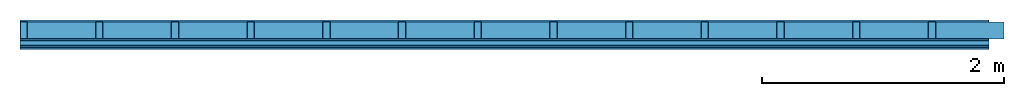
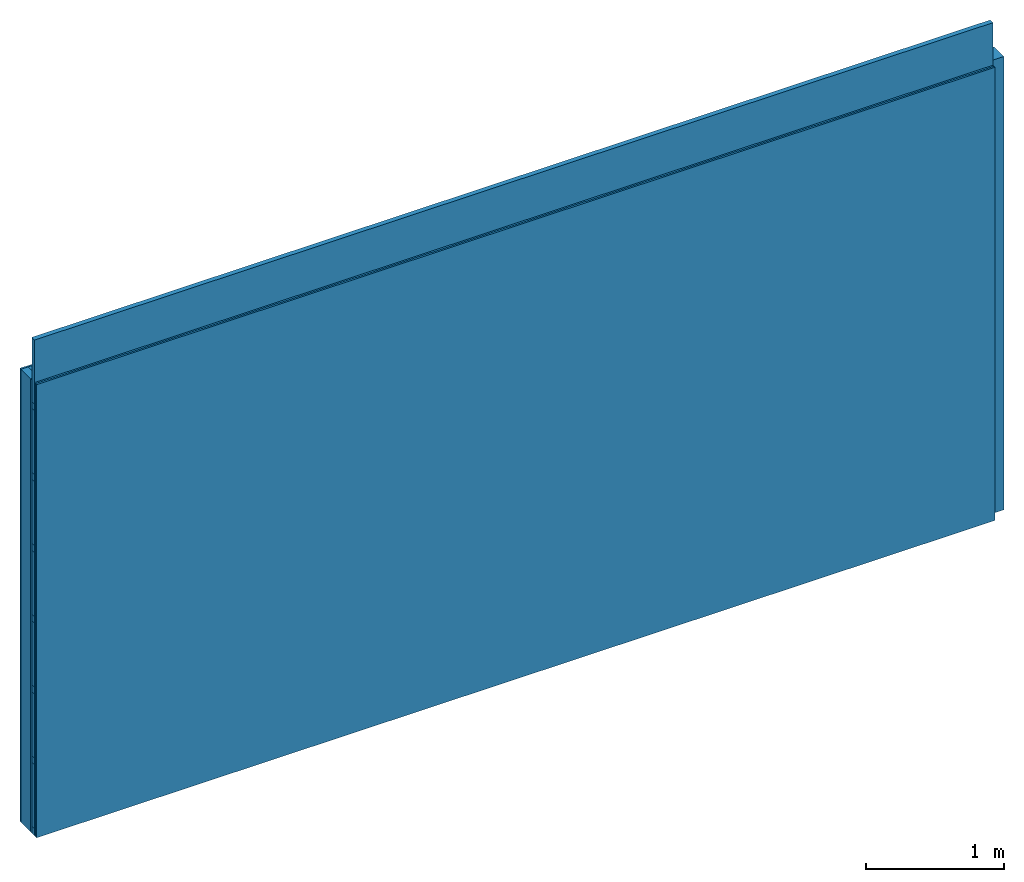
# One storey: 4 members, 4 plates, 1 element without a shape of its own.
"""IFC4 building model written with IfcOpenShell, lengths in metres."""

from ifc_helpers import new_model, si_unit, derived_unit, direction, frame, frame_2d, origin, origin_with_axes, place, context, project, spatial, rectangle, extrude, material, layer, layer_set, type_object, element, aggregate, save


model = new_model("IFC4")

# Units and contexts
plan_context = context("Plan", 3, precision=1e-05, world=origin(), true_north=direction((0.0, 1.0)))
model_context = context("Model", 3, precision=1e-05, world=origin(), true_north=direction((0.0, 1.0)))
ifc_project = project(units=[si_unit("LENGTHUNIT", "METRE"), derived_unit("SOUNDPRESSUREUNIT", [(si_unit("PRESSUREUNIT", "PASCAL", prefix="MICRO"), 0)]), si_unit("ENERGYUNIT", "JOULE", prefix="MEGA"), si_unit("MASSUNIT", "GRAM", prefix="KILO"), derived_unit("THERMALTRANSMITTANCEUNIT", [(si_unit("POWERUNIT", "WATT"), 1), (si_unit("AREAUNIT", "SQUARE_METRE"), -1), (si_unit("THERMODYNAMICTEMPERATUREUNIT", "KELVIN"), -1)]), derived_unit("AREADENSITYUNIT", [(si_unit("MASSUNIT", "GRAM", prefix="KILO"), 1), (si_unit("AREAUNIT", "SQUARE_METRE"), -1)]), derived_unit("USERDEFINED", [(si_unit("ENERGYUNIT", "JOULE", prefix="MEGA"), 1), (si_unit("AREAUNIT", "SQUARE_METRE"), -1)])], contexts=[plan_context, model_context])

# Site, building, storey
site = spatial("IfcSite", under=ifc_project)
building_placement = place(None, origin())
building = spatial("IfcBuilding", under=site, at=building_placement)
storey_placement = place(building_placement, origin())
storey = spatial("IfcBuildingStorey", under=building, at=storey_placement)

# Wall, members, plates
ifc_material_1 = material(Name="Glued joints")
ifc_layer_1 = layer(ifc_material_1, 0.0, Name="Surface")
ifc_material_2 = material(Category="03.007")
ifc_layer_2 = layer(ifc_material_2, 0.015, Name="1st layer")
ifc_material_3 = material(Name="of the art")
ifc_layer_3 = layer(ifc_material_3, 0.0, Name="Bond")
ifc_layer_4 = layer(None, 0.14, Name="Support")
ifc_layer_5 = layer(ifc_material_3, 0.0, Name="Bond")
ifc_layer_6 = layer(ifc_material_2, 0.015, Name="1st layer")
ifc_material_4 = material(Name="Substructure rigid")
ifc_layer_7 = layer(ifc_material_4, 0.0, Name="Coupling")
ifc_layer_8 = layer(None, 0.04, Name="Battens / profiles")
ifc_layer_9 = layer(ifc_material_2, 0.015, Name="Covering 1st layer")
ifc_layer_10 = layer(ifc_material_2, 0.015, Name="Covering 2nd layer")
ifc_layer_11 = layer(ifc_material_1, 0.0, Name="Surface")
ifc_layer_set = layer_set([ifc_layer_1, ifc_layer_2, ifc_layer_3, ifc_layer_4, ifc_layer_5, ifc_layer_6, ifc_layer_7, ifc_layer_8, ifc_layer_9, ifc_layer_10, ifc_layer_11])
wall_type = type_object("IfcWallType", Name="C0077", PredefinedType="NOTDEFINED", material=ifc_layer_set)
wall_placement = place(None, frame((0.0, 0.0, 0.0), z_axis=(0.0, -1.0, 0.0), x_axis=(1.0, 0.0, 0.0)))
wall = element("IfcWall", 1, at=wall_placement, inside=storey, type_object=wall_type, material=ifc_layer_set, Name="Wall #1")
ifc_material_5 = material()
member_1_placement = place(wall_placement, origin())
member_1 = element("IfcMember", 2, at=member_1_placement, material=ifc_material_5, Name="Support", context=plan_context, shape_type="SweptSolid", body=[
    extrude(rectangle(XDim=0.06, YDim=0.14, at=frame_2d((0.03, 0.07), x_axis=(1.0, 0.0))), frame((0.0, 4.0, 0.015), z_axis=(0.0, -1.0, 0.0), x_axis=(1.0, 0.0, 0.0)), (0.0, 0.0, 1.0), 4.0),
    extrude(rectangle(XDim=0.06, YDim=0.14, at=frame_2d((0.03, 0.07), x_axis=(1.0, 0.0))), frame((0.625, 4.0, 0.015), z_axis=(0.0, -1.0, 0.0), x_axis=(1.0, 0.0, 0.0)), (0.0, 0.0, 1.0), 4.0),
    extrude(rectangle(XDim=0.06, YDim=0.14, at=frame_2d((0.03, 0.07), x_axis=(1.0, 0.0))), frame((1.25, 4.0, 0.015), z_axis=(0.0, -1.0, 0.0), x_axis=(1.0, 0.0, 0.0)), (0.0, 0.0, 1.0), 4.0),
    extrude(rectangle(XDim=0.06, YDim=0.14, at=frame_2d((0.03, 0.07), x_axis=(1.0, 0.0))), frame((1.875, 4.0, 0.015), z_axis=(0.0, -1.0, 0.0), x_axis=(1.0, 0.0, 0.0)), (0.0, 0.0, 1.0), 4.0),
    extrude(rectangle(XDim=0.06, YDim=0.14, at=frame_2d((0.03, 0.07), x_axis=(1.0, 0.0))), frame((2.5, 4.0, 0.015), z_axis=(0.0, -1.0, 0.0), x_axis=(1.0, 0.0, 0.0)), (0.0, 0.0, 1.0), 4.0),
    extrude(rectangle(XDim=0.06, YDim=0.14, at=frame_2d((0.03, 0.07), x_axis=(1.0, 0.0))), frame((3.125, 4.0, 0.015), z_axis=(0.0, -1.0, 0.0), x_axis=(1.0, 0.0, 0.0)), (0.0, 0.0, 1.0), 4.0),
    extrude(rectangle(XDim=0.06, YDim=0.14, at=frame_2d((0.03, 0.07), x_axis=(1.0, 0.0))), frame((3.75, 4.0, 0.015), z_axis=(0.0, -1.0, 0.0), x_axis=(1.0, 0.0, 0.0)), (0.0, 0.0, 1.0), 4.0),
    extrude(rectangle(XDim=0.06, YDim=0.14, at=frame_2d((0.03, 0.07), x_axis=(1.0, 0.0))), frame((4.375, 4.0, 0.015), z_axis=(0.0, -1.0, 0.0), x_axis=(1.0, 0.0, 0.0)), (0.0, 0.0, 1.0), 4.0),
    extrude(rectangle(XDim=0.06, YDim=0.14, at=frame_2d((0.03, 0.07), x_axis=(1.0, 0.0))), frame((5.0, 4.0, 0.015), z_axis=(0.0, -1.0, 0.0), x_axis=(1.0, 0.0, 0.0)), (0.0, 0.0, 1.0), 4.0),
    extrude(rectangle(XDim=0.06, YDim=0.14, at=frame_2d((0.03, 0.07), x_axis=(1.0, 0.0))), frame((5.625, 4.0, 0.015), z_axis=(0.0, -1.0, 0.0), x_axis=(1.0, 0.0, 0.0)), (0.0, 0.0, 1.0), 4.0),
    extrude(rectangle(XDim=0.06, YDim=0.14, at=frame_2d((0.03, 0.07), x_axis=(1.0, 0.0))), frame((6.25, 4.0, 0.015), z_axis=(0.0, -1.0, 0.0), x_axis=(1.0, 0.0, 0.0)), (0.0, 0.0, 1.0), 4.0),
    extrude(rectangle(XDim=0.06, YDim=0.14, at=frame_2d((0.03, 0.07), x_axis=(1.0, 0.0))), frame((6.875, 4.0, 0.015), z_axis=(0.0, -1.0, 0.0), x_axis=(1.0, 0.0, 0.0)), (0.0, 0.0, 1.0), 4.0),
    extrude(rectangle(XDim=0.06, YDim=0.14, at=frame_2d((0.03, 0.07), x_axis=(1.0, 0.0))), frame((7.5, 4.0, 0.015), z_axis=(0.0, -1.0, 0.0), x_axis=(1.0, 0.0, 0.0)), (0.0, 0.0, 1.0), 4.0),
])
ifc_material_6 = material()
member_2_placement = place(wall_placement, origin())
member_2 = element("IfcMember", 3, at=member_2_placement, material=ifc_material_6, Name="Cavity", context=plan_context, shape_type="SweptSolid", body=[
    extrude(rectangle(XDim=0.565, YDim=0.14, at=frame_2d((0.2825, 0.07), x_axis=(1.0, 0.0))), frame((0.06, 4.0, 0.015), z_axis=(0.0, -1.0, 0.0), x_axis=(1.0, 0.0, 0.0)), (0.0, 0.0, 1.0), 4.0),
    extrude(rectangle(XDim=0.565, YDim=0.14, at=frame_2d((0.2825, 0.07), x_axis=(1.0, 0.0))), frame((0.685, 4.0, 0.015), z_axis=(0.0, -1.0, 0.0), x_axis=(1.0, 0.0, 0.0)), (0.0, 0.0, 1.0), 4.0),
    extrude(rectangle(XDim=0.565, YDim=0.14, at=frame_2d((0.2825, 0.07), x_axis=(1.0, 0.0))), frame((1.31, 4.0, 0.015), z_axis=(0.0, -1.0, 0.0), x_axis=(1.0, 0.0, 0.0)), (0.0, 0.0, 1.0), 4.0),
    extrude(rectangle(XDim=0.565, YDim=0.14, at=frame_2d((0.2825, 0.07), x_axis=(1.0, 0.0))), frame((1.935, 4.0, 0.015), z_axis=(0.0, -1.0, 0.0), x_axis=(1.0, 0.0, 0.0)), (0.0, 0.0, 1.0), 4.0),
    extrude(rectangle(XDim=0.565, YDim=0.14, at=frame_2d((0.2825, 0.07), x_axis=(1.0, 0.0))), frame((2.56, 4.0, 0.015), z_axis=(0.0, -1.0, 0.0), x_axis=(1.0, 0.0, 0.0)), (0.0, 0.0, 1.0), 4.0),
    extrude(rectangle(XDim=0.565, YDim=0.14, at=frame_2d((0.2825, 0.07), x_axis=(1.0, 0.0))), frame((3.185, 4.0, 0.015), z_axis=(0.0, -1.0, 0.0), x_axis=(1.0, 0.0, 0.0)), (0.0, 0.0, 1.0), 4.0),
    extrude(rectangle(XDim=0.565, YDim=0.14, at=frame_2d((0.2825, 0.07), x_axis=(1.0, 0.0))), frame((3.81, 4.0, 0.015), z_axis=(0.0, -1.0, 0.0), x_axis=(1.0, 0.0, 0.0)), (0.0, 0.0, 1.0), 4.0),
    extrude(rectangle(XDim=0.565, YDim=0.14, at=frame_2d((0.2825, 0.07), x_axis=(1.0, 0.0))), frame((4.435, 4.0, 0.015), z_axis=(0.0, -1.0, 0.0), x_axis=(1.0, 0.0, 0.0)), (0.0, 0.0, 1.0), 4.0),
    extrude(rectangle(XDim=0.565, YDim=0.14, at=frame_2d((0.2825, 0.07), x_axis=(1.0, 0.0))), frame((5.06, 4.0, 0.015), z_axis=(0.0, -1.0, 0.0), x_axis=(1.0, 0.0, 0.0)), (0.0, 0.0, 1.0), 4.0),
    extrude(rectangle(XDim=0.565, YDim=0.14, at=frame_2d((0.2825, 0.07), x_axis=(1.0, 0.0))), frame((5.685, 4.0, 0.015), z_axis=(0.0, -1.0, 0.0), x_axis=(1.0, 0.0, 0.0)), (0.0, 0.0, 1.0), 4.0),
    extrude(rectangle(XDim=0.565, YDim=0.14, at=frame_2d((0.2825, 0.07), x_axis=(1.0, 0.0))), frame((6.31, 4.0, 0.015), z_axis=(0.0, -1.0, 0.0), x_axis=(1.0, 0.0, 0.0)), (0.0, 0.0, 1.0), 4.0),
    extrude(rectangle(XDim=0.565, YDim=0.14, at=frame_2d((0.2825, 0.07), x_axis=(1.0, 0.0))), frame((6.935, 4.0, 0.015), z_axis=(0.0, -1.0, 0.0), x_axis=(1.0, 0.0, 0.0)), (0.0, 0.0, 1.0), 4.0),
    extrude(rectangle(XDim=0.565, YDim=0.14, at=frame_2d((0.2825, 0.07), x_axis=(1.0, 0.0))), frame((7.56, 4.0, 0.015), z_axis=(0.0, -1.0, 0.0), x_axis=(1.0, 0.0, 0.0)), (0.0, 0.0, 1.0), 4.0),
])
ifc_material_7 = material()
member_3_placement = place(wall_placement, origin())
member_3 = element("IfcMember", 4, at=member_3_placement, material=ifc_material_7, Name="Battens / profiles", context=plan_context, shape_type="SweptSolid", body=[
    extrude(rectangle(XDim=0.06, YDim=0.04, at=frame_2d((0.03, 0.02), x_axis=(1.0, 0.0))), frame((0.0, 0.0, 0.17), z_axis=(1.0, 0.0, 0.0), x_axis=(0.0, 1.0, 0.0)), (0.0, 0.0, 1.0), 8.0),
    extrude(rectangle(XDim=0.06, YDim=0.04, at=frame_2d((0.03, 0.02), x_axis=(1.0, 0.0))), frame((0.0, 0.625, 0.17), z_axis=(1.0, 0.0, 0.0), x_axis=(0.0, 1.0, 0.0)), (0.0, 0.0, 1.0), 8.0),
    extrude(rectangle(XDim=0.06, YDim=0.04, at=frame_2d((0.03, 0.02), x_axis=(1.0, 0.0))), frame((0.0, 1.25, 0.17), z_axis=(1.0, 0.0, 0.0), x_axis=(0.0, 1.0, 0.0)), (0.0, 0.0, 1.0), 8.0),
    extrude(rectangle(XDim=0.06, YDim=0.04, at=frame_2d((0.03, 0.02), x_axis=(1.0, 0.0))), frame((0.0, 1.875, 0.17), z_axis=(1.0, 0.0, 0.0), x_axis=(0.0, 1.0, 0.0)), (0.0, 0.0, 1.0), 8.0),
    extrude(rectangle(XDim=0.06, YDim=0.04, at=frame_2d((0.03, 0.02), x_axis=(1.0, 0.0))), frame((0.0, 2.5, 0.17), z_axis=(1.0, 0.0, 0.0), x_axis=(0.0, 1.0, 0.0)), (0.0, 0.0, 1.0), 8.0),
    extrude(rectangle(XDim=0.06, YDim=0.04, at=frame_2d((0.03, 0.02), x_axis=(1.0, 0.0))), frame((0.0, 3.125, 0.17), z_axis=(1.0, 0.0, 0.0), x_axis=(0.0, 1.0, 0.0)), (0.0, 0.0, 1.0), 8.0),
    extrude(rectangle(XDim=0.06, YDim=0.04, at=frame_2d((0.03, 0.02), x_axis=(1.0, 0.0))), frame((0.0, 3.75, 0.17), z_axis=(1.0, 0.0, 0.0), x_axis=(0.0, 1.0, 0.0)), (0.0, 0.0, 1.0), 8.0),
])
member_4_placement = place(wall_placement, origin())
member_4 = element("IfcMember", 5, at=member_4_placement, material=ifc_material_6, Name="Cavity", context=plan_context, shape_type="SweptSolid", body=[
    extrude(rectangle(XDim=0.565, YDim=0.04, at=frame_2d((0.2825, 0.02), x_axis=(1.0, 0.0))), frame((0.0, 0.06, 0.17), z_axis=(1.0, 0.0, 0.0), x_axis=(0.0, 1.0, 0.0)), (0.0, 0.0, 1.0), 8.0),
    extrude(rectangle(XDim=0.565, YDim=0.04, at=frame_2d((0.2825, 0.02), x_axis=(1.0, 0.0))), frame((0.0, 0.685, 0.17), z_axis=(1.0, 0.0, 0.0), x_axis=(0.0, 1.0, 0.0)), (0.0, 0.0, 1.0), 8.0),
    extrude(rectangle(XDim=0.565, YDim=0.04, at=frame_2d((0.2825, 0.02), x_axis=(1.0, 0.0))), frame((0.0, 1.31, 0.17), z_axis=(1.0, 0.0, 0.0), x_axis=(0.0, 1.0, 0.0)), (0.0, 0.0, 1.0), 8.0),
    extrude(rectangle(XDim=0.565, YDim=0.04, at=frame_2d((0.2825, 0.02), x_axis=(1.0, 0.0))), frame((0.0, 1.935, 0.17), z_axis=(1.0, 0.0, 0.0), x_axis=(0.0, 1.0, 0.0)), (0.0, 0.0, 1.0), 8.0),
    extrude(rectangle(XDim=0.565, YDim=0.04, at=frame_2d((0.2825, 0.02), x_axis=(1.0, 0.0))), frame((0.0, 2.56, 0.17), z_axis=(1.0, 0.0, 0.0), x_axis=(0.0, 1.0, 0.0)), (0.0, 0.0, 1.0), 8.0),
    extrude(rectangle(XDim=0.565, YDim=0.04, at=frame_2d((0.2825, 0.02), x_axis=(1.0, 0.0))), frame((0.0, 3.185, 0.17), z_axis=(1.0, 0.0, 0.0), x_axis=(0.0, 1.0, 0.0)), (0.0, 0.0, 1.0), 8.0),
    extrude(rectangle(XDim=0.565, YDim=0.04, at=frame_2d((0.2825, 0.02), x_axis=(1.0, 0.0))), frame((0.0, 3.81, 0.17), z_axis=(1.0, 0.0, 0.0), x_axis=(0.0, 1.0, 0.0)), (0.0, 0.0, 1.0), 8.0),
])
plate_1_placement = place(wall_placement, origin())
plate_1 = element("IfcPlate", 6, at=plate_1_placement, material=ifc_material_2, Name="1st layer", context=plan_context, shape_type="SweptSolid", body=[
    extrude(rectangle(XDim=8.0, YDim=4.0, at=frame_2d((4.0, 2.0), x_axis=(1.0, 0.0))), origin_with_axes(), (0.0, 0.0, 1.0), 0.015),
])
plate_2_placement = place(wall_placement, origin())
plate_2 = element("IfcPlate", 7, at=plate_2_placement, material=ifc_material_2, Name="1st layer", context=plan_context, shape_type="SweptSolid", body=[
    extrude(rectangle(XDim=8.0, YDim=4.0, at=frame_2d((4.0, 2.0), x_axis=(1.0, 0.0))), frame((0.0, 0.0, 0.155), z_axis=(0.0, 0.0, 1.0), x_axis=(1.0, 0.0, 0.0)), (0.0, 0.0, 1.0), 0.015),
])
plate_3_placement = place(wall_placement, origin())
plate_3 = element("IfcPlate", 8, at=plate_3_placement, material=ifc_material_2, Name="Covering 1st layer", context=plan_context, shape_type="SweptSolid", body=[
    extrude(rectangle(XDim=8.0, YDim=4.0, at=frame_2d((4.0, 2.0), x_axis=(1.0, 0.0))), frame((0.0, 0.0, 0.21), z_axis=(0.0, 0.0, 1.0), x_axis=(1.0, 0.0, 0.0)), (0.0, 0.0, 1.0), 0.015),
])
plate_4_placement = place(wall_placement, origin())
plate_4 = element("IfcPlate", 9, at=plate_4_placement, material=ifc_material_2, Name="Covering 2nd layer", context=plan_context, shape_type="SweptSolid", body=[
    extrude(rectangle(XDim=8.0, YDim=4.0, at=frame_2d((4.0, 2.0), x_axis=(1.0, 0.0))), frame((0.0, 0.0, 0.225), z_axis=(0.0, 0.0, 1.0), x_axis=(1.0, 0.0, 0.0)), (0.0, 0.0, 1.0), 0.015),
])
aggregate(wall, [plate_1, member_1, member_2, plate_2, member_3, member_4, plate_3, plate_4])

save(model, "model.ifc")
